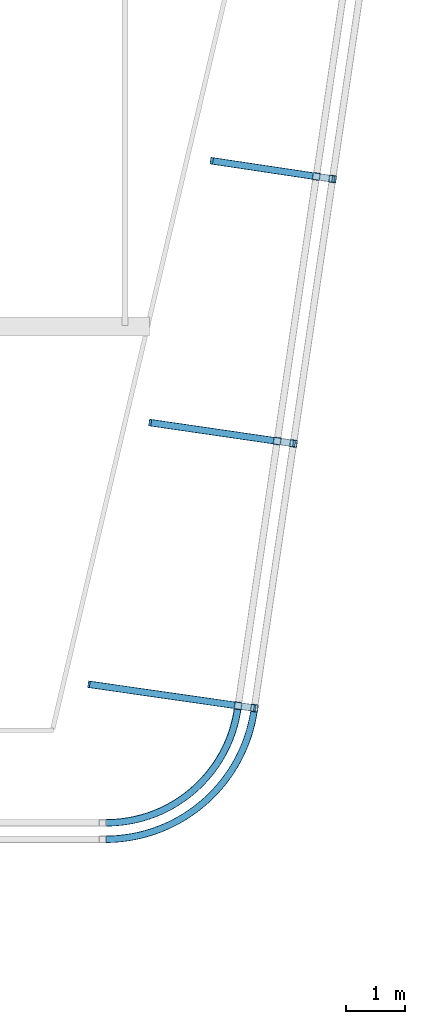
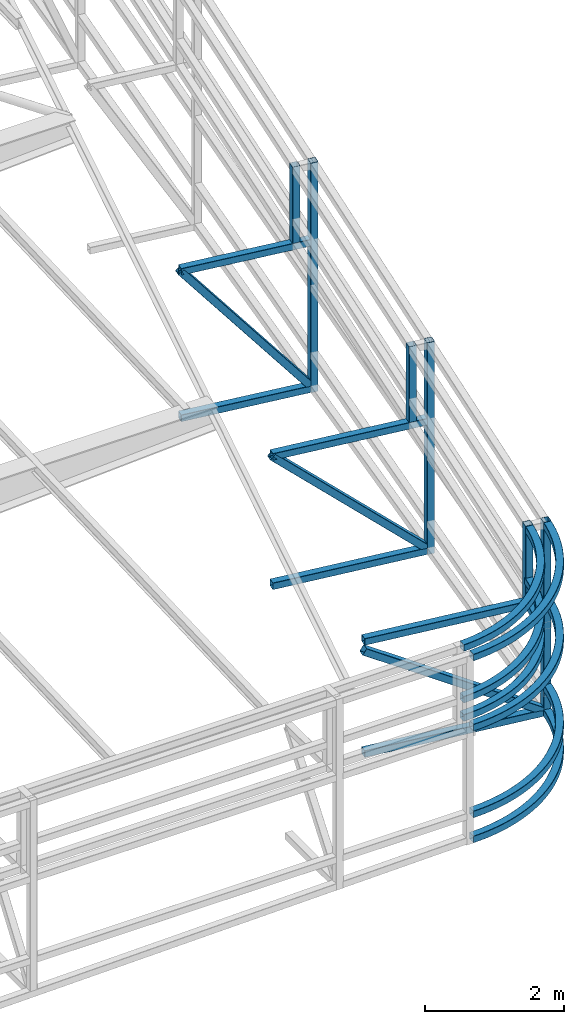
# One storey, part 118 of 215: 19 beams, 3 members, 22 elements without a shape of their own.
"""IFC2X3 building model written with IfcOpenShell, lengths in millimetres."""

from ifc_helpers import new_model, entity, si_unit, frame, origin_with_axes, origin_2d_with_axis, place, context, subcontext, project, spatial, hollow_rectangle, extrude, material, type_object, element, aggregate, save


model = new_model("IFC2X3")

# Units and contexts
model_context = context("Model", 3, precision=1e-05, world=origin_with_axes())
body_context = subcontext(model_context, "Body", "Model", "MODEL_VIEW")
ifc_project = project(units=[si_unit("LENGTHUNIT", "METRE", prefix="MILLI"), si_unit("AREAUNIT", "SQUARE_METRE"), si_unit("VOLUMEUNIT", "CUBIC_METRE"), si_unit("MASSUNIT", "GRAM", prefix="KILO"), si_unit("TIMEUNIT", "SECOND"), si_unit("PLANEANGLEUNIT", "RADIAN"), si_unit("SOLIDANGLEUNIT", "STERADIAN"), si_unit("THERMODYNAMICTEMPERATUREUNIT", "DEGREE_CELSIUS"), si_unit("LUMINOUSINTENSITYUNIT", "LUMEN")], contexts=[model_context])

# Site, building, storey
site_placement = place(None, origin_with_axes())
site = spatial("IfcSite", under=ifc_project, at=site_placement, CompositionType="ELEMENT")
building_placement = place(site_placement, origin_with_axes())
building = spatial("IfcBuilding", under=site, at=building_placement, Name="Undefined", CompositionType="ELEMENT")
storey_placement = place(building_placement, origin_with_axes())
storey = spatial("IfcBuildingStorey", under=building, at=storey_placement, Name="Undefined", CompositionType="ELEMENT", Elevation=0.0)

# Assembly, beam
assembly_1_placement = place(storey_placement, origin_with_axes())
assembly_1 = element("IfcElementAssembly", 1, at=assembly_1_placement, inside=storey, Name="Steel Assembly", AssemblyPlace="NOTDEFINED", PredefinedType="RIGID_FRAME")
ifc_material = material(Name="STEEL/S275JR")
beam_type = type_object("IfcBeamType", PredefinedType="NOTDEFINED")
beam_1_placement = place(assembly_1_placement, frame((146986.107821461, 33421.3509029512, 3370.20225622604), z_axis=(0.0249379879919667, 0.0219553309929332, -0.999447877678423), x_axis=(0.750140522937086, 0.660443226944612, 0.0332255899972135)))
beam_1 = element("IfcBeam", 2, at=beam_1_placement, type_object=beam_type, material=ifc_material, Name="LISSE", context=body_context, shape_type="SweptSolid", body=[
    entity("IfcRevolvedAreaSolid", entity("IfcRectangleHollowProfileDef", "AREA", None, entity("IfcAxis2Placement2D", entity("IfcCartesianPoint", [0.0, 0.0]), entity("IfcDirection", [1.0, 0.0])), 120.0, 120.0, 4.0, 4.0, 8.0), entity("IfcAxis2Placement3D", entity("IfcCartesianPoint", [2982.09033256195, -3.31258300091533e-13, 4.54747350886464e-13]), entity("IfcDirection", [-0.751481205288007, 0.659754498354414, 1.12605010136892e-18]), entity("IfcDirection", [-0.659754498354413, -0.751481205288007, -1.28260662034445e-18])), entity("IfcAxis1Placement", entity("IfcCartesianPoint", [2260.0, 0.0, 0.0]), entity("IfcDirection", [0.0, 1.0, 0.0])), 1.44098404733524),
])
aggregate(assembly_1, [beam_1])

assembly_2_placement = place(storey_placement, origin_with_axes())
assembly_2 = element("IfcElementAssembly", 3, at=assembly_2_placement, inside=storey, Name="Steel Assembly", AssemblyPlace="NOTDEFINED", PredefinedType="RIGID_FRAME")
beam_2_placement = place(assembly_2_placement, frame((149229.547572394, 35412.1655569566, 4443.67703251226), z_axis=(0.989924604068383, -0.141595474009783, 0.0), x_axis=(0.0, 0.0, -1.0)))
beam_2 = element("IfcBeam", 4, at=beam_2_placement, type_object=beam_type, material=ifc_material, Name="LISSE", context=body_context, shape_type="SweptSolid", body=[
    extrude(hollow_rectangle(XDim=120.0, YDim=120.0, WallThickness=4.0, InnerFilletRadius=4.0, OuterFilletRadius=8.0, at=origin_2d_with_axis()), frame((1326.42375686985, 0.0, 0.0), z_axis=(-1.0, 0.0, 0.0), x_axis=(-6.93889390390723e-18, -1.0, -3.46944695195361e-18)), (0.0, 0.0, 1.0), 1326.4),
])
aggregate(assembly_2, [beam_2])

assembly_3_placement = place(storey_placement, origin_with_axes())
assembly_3 = element("IfcElementAssembly", 5, at=assembly_3_placement, inside=storey, Name="Steel Assembly", AssemblyPlace="NOTDEFINED", PredefinedType="RIGID_FRAME")
beam_3_placement = place(assembly_3_placement, frame((146984.608837866, 33420.048579936, 3050.34013730541), z_axis=(0.00179264899915949, 0.00154833799926593, -0.999997194525568), x_axis=(0.756640650044633, 0.653826671038565, 0.00236874200013964)))
beam_3 = element("IfcBeam", 6, at=beam_3_placement, type_object=beam_type, material=ifc_material, Name="LISSE", context=body_context, shape_type="SweptSolid", body=[
    entity("IfcRevolvedAreaSolid", entity("IfcRectangleHollowProfileDef", "AREA", None, entity("IfcAxis2Placement2D", entity("IfcCartesianPoint", [0.0, 0.0]), entity("IfcDirection", [1.0, 0.0])), 120.0, 120.0, 4.0, 4.0, 8.0), entity("IfcAxis2Placement3D", entity("IfcCartesianPoint", [2955.85779626077, -1.44083565119215e-11, -4.54747350886464e-13]), entity("IfcDirection", [-0.756537044049607, 0.653950839880708, 4.02975277534255e-20]), entity("IfcDirection", [-0.653950839880708, -0.756537044049607, -4.66190586048407e-20])), entity("IfcAxis1Placement", entity("IfcCartesianPoint", [2260.0, 0.0, 0.0]), entity("IfcDirection", [0.0, 1.0, 0.0])), 1.42558999007248),
])
aggregate(assembly_3, [beam_3])

assembly_4_placement = place(storey_placement, origin_with_axes())
assembly_4 = element("IfcElementAssembly", 7, at=assembly_4_placement, inside=storey, Name="Steel Assembly", AssemblyPlace="NOTDEFINED", PredefinedType="RIGID_FRAME")
beam_4_placement = place(assembly_4_placement, frame((146985.996338329, 33421.2851109319, 4277.74721442107), z_axis=(0.0253519010019989, 0.0218986280017402, -0.999438708079303), x_axis=(0.756342078056285, 0.653317987048616, 0.0335002800024929)))
beam_4 = element("IfcBeam", 8, at=beam_4_placement, type_object=beam_type, material=ifc_material, Name="LISSE", context=body_context, shape_type="SweptSolid", body=[
    entity("IfcRevolvedAreaSolid", entity("IfcRectangleHollowProfileDef", "AREA", None, entity("IfcAxis2Placement2D", entity("IfcCartesianPoint", [0.0, 0.0]), entity("IfcDirection", [1.0, 0.0])), 120.0, 120.0, 4.0, 4.0, 8.0), entity("IfcAxis2Placement3D", entity("IfcCartesianPoint", [2957.63905920273, -1.46888710049272e-11, 9.53714342788421e-13]), entity("IfcDirection", [-0.756196217688976, 0.654344924602374, 1.39294531843258e-17]), entity("IfcDirection", [-0.654344924602374, -0.756196217688976, 5.11104750660968e-18])), entity("IfcAxis1Placement", entity("IfcCartesianPoint", [2260.0, 0.0, 0.0]), entity("IfcDirection", [0.0, 1.0, 0.0])), 1.42663203687007),
])
aggregate(assembly_4, [beam_4])

assembly_5_placement = place(storey_placement, origin_with_axes())
assembly_5 = element("IfcElementAssembly", 9, at=assembly_5_placement, inside=storey, Name="Steel Assembly", AssemblyPlace="NOTDEFINED", PredefinedType="RIGID_FRAME")
beam_5_placement = place(assembly_5_placement, frame((146985.775961301, 33141.0905904749, 4280.15728586742), z_axis=(0.0214822509927782, 0.0185404799937631, -0.999597300663564), x_axis=(0.756721212900151, 0.653121557913824, 0.0283766899962559)))
beam_5 = element("IfcBeam", 10, at=beam_5_placement, type_object=beam_type, material=ifc_material, Name="LISSE", context=body_context, shape_type="SweptSolid", body=[
    entity("IfcRevolvedAreaSolid", entity("IfcRectangleHollowProfileDef", "AREA", None, entity("IfcAxis2Placement2D", entity("IfcCartesianPoint", [0.0, 0.0]), entity("IfcDirection", [1.0, 0.0])), 120.0, 120.0, 4.0, 4.0, 8.0), entity("IfcAxis2Placement3D", entity("IfcCartesianPoint", [3321.12292680895, 1.47960032481586e-11, 9.09494701772928e-13]), entity("IfcDirection", [-0.761081025736955, 0.648656821642373, -1.46472156336757e-18]), entity("IfcDirection", [-0.648656821642373, -0.761081025736955, 1.71858485515387e-18])), entity("IfcAxis1Placement", entity("IfcCartesianPoint", [2560.0, 0.0, 0.0]), entity("IfcDirection", [0.0, 1.0, 0.0])), 1.41163655377641),
])
aggregate(assembly_5, [beam_5])

assembly_6_placement = place(storey_placement, origin_with_axes())
assembly_6 = element("IfcElementAssembly", 11, at=assembly_6_placement, inside=storey, Name="Steel Assembly", AssemblyPlace="NOTDEFINED", PredefinedType="RIGID_FRAME")
beam_6_placement = place(assembly_6_placement, frame((146984.478276513, 33139.987285832, 3051.71855063196), z_axis=(0.0, 0.0, -1.0), x_axis=(0.757026076418502, 0.653384664361208, 1.00000000707343e-08)))
beam_6 = element("IfcBeam", 12, at=beam_6_placement, type_object=beam_type, material=ifc_material, Name="LISSE", context=body_context, shape_type="SweptSolid", body=[
    entity("IfcRevolvedAreaSolid", entity("IfcRectangleHollowProfileDef", "AREA", None, entity("IfcAxis2Placement2D", entity("IfcCartesianPoint", [0.0, 0.0]), entity("IfcDirection", [1.0, 0.0])), 120.0, 120.0, 4.0, 4.0, 8.0), entity("IfcAxis2Placement3D", entity("IfcCartesianPoint", [3319.78546821593, 1.48220415771816e-11, 4.54747147677863e-13]), entity("IfcDirection", [-0.761303583900054, 0.648395599260924, -2.2051122628262e-23]), entity("IfcDirection", [-0.648395599260925, -0.761303583900054, 1.20295332207293e-22])), entity("IfcAxis1Placement", entity("IfcCartesianPoint", [2560.0, 0.0, 0.0]), entity("IfcDirection", [0.0, 1.0, 0.0])), 1.4109502032255),
])
aggregate(assembly_6, [beam_6])

assembly_7_placement = place(storey_placement, origin_with_axes())
assembly_7 = element("IfcElementAssembly", 13, at=assembly_7_placement, inside=storey, Name="Steel Assembly", AssemblyPlace="NOTDEFINED", PredefinedType="RIGID_FRAME")
beam_7_placement = place(assembly_7_placement, frame((146984.478275593, 33139.9863115836, 1528.87963197618), z_axis=(0.0, 0.0, -1.0), x_axis=(0.757026076418502, 0.653384664361208, 1.00000000707343e-08)))
beam_7 = element("IfcBeam", 14, at=beam_7_placement, type_object=beam_type, material=ifc_material, Name="LISSE", context=body_context, shape_type="SweptSolid", body=[
    entity("IfcRevolvedAreaSolid", entity("IfcRectangleHollowProfileDef", "AREA", None, entity("IfcAxis2Placement2D", entity("IfcCartesianPoint", [0.0, 0.0]), entity("IfcDirection", [1.0, 0.0])), 120.0, 120.0, 4.0, 4.0, 8.0), entity("IfcAxis2Placement3D", entity("IfcCartesianPoint", [3319.78546821593, 1.48220415771816e-11, 4.54747147677863e-13]), entity("IfcDirection", [-0.761303583900054, 0.648395599260924, -2.2051122628262e-23]), entity("IfcDirection", [-0.648395599260925, -0.761303583900054, 1.20295332207293e-22])), entity("IfcAxis1Placement", entity("IfcCartesianPoint", [2560.0, 0.0, 0.0]), entity("IfcDirection", [0.0, 1.0, 0.0])), 1.41095020268318),
])
aggregate(assembly_7, [beam_7])

assembly_8_placement = place(storey_placement, origin_with_axes())
assembly_8 = element("IfcElementAssembly", 15, at=assembly_8_placement, inside=storey, Name="Steel Assembly", AssemblyPlace="NOTDEFINED", PredefinedType="RIGID_FRAME")
beam_8_placement = place(assembly_8_placement, frame((150559.754278982, 44413.5248230028, 4817.75277962869), z_axis=(0.989008242586695, -0.147860393938214, -1.14999999775283e-07), x_axis=(9.82199999785384e-06, 6.6470999981142e-05, -0.999999997742567)))
beam_8 = element("IfcBeam", 16, at=beam_8_placement, type_object=beam_type, material=ifc_material, Name="LISSE", context=body_context, shape_type="SweptSolid", body=[
    extrude(hollow_rectangle(XDim=120.0, YDim=120.0, WallThickness=4.0, InnerFilletRadius=4.0, OuterFilletRadius=8.0, at=origin_2d_with_axis()), frame((1339.42166511812, 0.0, 4.25450355232975e-19), z_axis=(-1.0, 0.0, 0.0), x_axis=(-6.93889390390723e-18, -1.0, -3.46944695195361e-18)), (0.0, 0.0, 1.0), 1339.4),
])
aggregate(assembly_8, [beam_8])

assembly_9_placement = place(storey_placement, origin_with_axes())
assembly_9 = element("IfcElementAssembly", 17, at=assembly_9_placement, inside=storey, Name="Steel Assembly", AssemblyPlace="NOTDEFINED", PredefinedType="RIGID_FRAME")
beam_9_placement = place(assembly_9_placement, frame((150836.550065716, 44371.8015430601, 4817.75278122506), z_axis=(0.989008242586695, -0.147860393938214, -1.14999999775283e-07), x_axis=(0.0, 0.0, -1.0)))
beam_9 = element("IfcBeam", 18, at=beam_9_placement, type_object=beam_type, material=ifc_material, Name="LISSE", context=body_context, shape_type="SweptSolid", body=[
    extrude(hollow_rectangle(XDim=120.0, YDim=120.0, WallThickness=4.0, InnerFilletRadius=4.0, OuterFilletRadius=8.0, at=origin_2d_with_axis()), frame((4028.88398977728, 0.0, 0.0), z_axis=(-1.0, 0.0, 0.0), x_axis=(-6.93889390390723e-18, -1.0, -3.46944695195361e-18)), (0.0, 0.0, 1.0), 4028.9),
])
aggregate(assembly_9, [beam_9])

assembly_10_placement = place(storey_placement, origin_with_axes())
assembly_10 = element("IfcElementAssembly", 19, at=assembly_10_placement, inside=storey, Name="Steel Assembly", AssemblyPlace="NOTDEFINED", PredefinedType="RIGID_FRAME")
beam_10_placement = place(assembly_10_placement, frame((148802.604779655, 44677.2956269249, 3418.33112434851), z_axis=(0.0, 0.0, 1.0), x_axis=(0.98891981087804, -0.148450690981692, 0.0)))
beam_10 = element("IfcBeam", 20, at=beam_10_placement, type_object=beam_type, material=ifc_material, Name="LISSE", context=body_context, shape_type="SweptSolid", body=[
    extrude(hollow_rectangle(XDim=120.0, YDim=120.0, WallThickness=4.0, InnerFilletRadius=4.0, OuterFilletRadius=8.0, at=origin_2d_with_axis()), frame((2046.83693117877, 1.45519152283669e-11, 0.0), z_axis=(-1.0, 0.0, 0.0), x_axis=(-6.93889390390723e-18, -1.0, -3.46944695195361e-18)), (0.0, 0.0, 1.0), 2046.8),
])
aggregate(assembly_10, [beam_10])

assembly_11_placement = place(storey_placement, origin_with_axes())
assembly_11 = element("IfcElementAssembly", 21, at=assembly_11_placement, inside=storey, Name="Steel Assembly", AssemblyPlace="NOTDEFINED", PredefinedType="RIGID_FRAME")
beam_11_placement = place(assembly_11_placement, frame((148802.591639564, 44677.2067034657, 848.868796747961), z_axis=(0.0, 0.0, 1.0), x_axis=(0.988919944781477, -0.148449798967196, 0.0)))
beam_11 = element("IfcBeam", 22, at=beam_11_placement, type_object=beam_type, material=ifc_material, Name="LISSE", context=body_context, shape_type="SweptSolid", body=[
    extrude(hollow_rectangle(XDim=120.0, YDim=120.0, WallThickness=4.0, InnerFilletRadius=4.0, OuterFilletRadius=8.0, at=origin_2d_with_axis()), frame((2046.83701684264, 1.4495104088773e-11, -8.12689870746292e-20), z_axis=(-1.0, 0.0, 0.0), x_axis=(-6.93889390390723e-18, -1.0, -3.46944695195361e-18)), (0.0, 0.0, 1.0), 2046.8),
])
aggregate(assembly_11, [beam_11])

assembly_12_placement = place(storey_placement, origin_with_axes())
assembly_12 = element("IfcElementAssembly", 23, at=assembly_12_placement, inside=storey, Name="Steel Assembly", AssemblyPlace="NOTDEFINED", PredefinedType="RIGID_FRAME")
beam_12_placement = place(assembly_12_placement, frame((149894.828068224, 39912.8547542987, 4626.55931463744), z_axis=(0.989369699093649, -0.145422139013767, 5.09999999897515e-08), x_axis=(9.82199999785384e-06, 6.6470999981142e-05, -0.999999997742567)))
beam_12 = element("IfcBeam", 24, at=beam_12_placement, type_object=beam_type, material=ifc_material, Name="LISSE", context=body_context, shape_type="SweptSolid", body=[
    extrude(hollow_rectangle(XDim=120.0, YDim=120.0, WallThickness=4.0, InnerFilletRadius=4.0, OuterFilletRadius=8.0, at=origin_2d_with_axis()), frame((1328.10102284344, 3.59982503561769e-17, -2.91038295163497e-11), z_axis=(-1.0, 0.0, 0.0), x_axis=(-6.93889390390723e-18, -1.0, -3.46944695195361e-18)), (0.0, 0.0, 1.0), 1328.1),
])
aggregate(assembly_12, [beam_12])

assembly_13_placement = place(storey_placement, origin_with_axes())
assembly_13 = element("IfcElementAssembly", 25, at=assembly_13_placement, inside=storey, Name="Steel Assembly", AssemblyPlace="NOTDEFINED", PredefinedType="RIGID_FRAME")
beam_13_placement = place(assembly_13_placement, frame((150171.856743916, 39872.1743222594, 4626.55930628644), z_axis=(0.989369699093649, -0.145422139013767, 5.09999999897515e-08), x_axis=(0.0, 0.0, -1.0)))
beam_13 = element("IfcBeam", 26, at=beam_13_placement, type_object=beam_type, material=ifc_material, Name="LISSE", context=body_context, shape_type="SweptSolid", body=[
    extrude(hollow_rectangle(XDim=120.0, YDim=120.0, WallThickness=4.0, InnerFilletRadius=4.0, OuterFilletRadius=8.0, at=origin_2d_with_axis()), frame((3717.80955508578, 0.0, 0.0), z_axis=(-1.0, 0.0, 0.0), x_axis=(-6.93889390390723e-18, -1.0, -3.46944695195361e-18)), (0.0, 0.0, 1.0), 3717.8),
])
aggregate(assembly_13, [beam_13])

assembly_14_placement = place(storey_placement, origin_with_axes())
assembly_14 = element("IfcElementAssembly", 27, at=assembly_14_placement, inside=storey, Name="Steel Assembly", AssemblyPlace="NOTDEFINED", PredefinedType="RIGID_FRAME")
beam_14_placement = place(assembly_14_placement, frame((147753.372346972, 40224.4947308677, 3238.45829173692), z_axis=(0.0, 0.0, 1.0), x_axis=(0.989558721916091, -0.144130273987778, 0.0)))
beam_14 = element("IfcBeam", 28, at=beam_14_placement, type_object=beam_type, material=ifc_material, Name="LISSE", context=body_context, shape_type="SweptSolid", body=[
    extrude(hollow_rectangle(XDim=120.0, YDim=120.0, WallThickness=4.0, InnerFilletRadius=4.0, OuterFilletRadius=8.0, at=origin_2d_with_axis()), frame((2434.01302481014, 6.75574325595442e-14, 4.54747350886464e-13), z_axis=(-1.0, 0.0, 0.0), x_axis=(-6.93889390390723e-18, -1.0, -3.46944695195361e-18)), (0.0, 0.0, 1.0), 2434.0),
])
aggregate(assembly_14, [beam_14])

assembly_15_placement = place(storey_placement, origin_with_axes())
assembly_15 = element("IfcElementAssembly", 29, at=assembly_15_placement, inside=storey, Name="Steel Assembly", AssemblyPlace="NOTDEFINED", PredefinedType="RIGID_FRAME")
beam_15_placement = place(assembly_15_placement, frame((147753.359206235, 40224.4058074942, 968.749756541968), z_axis=(0.0, 0.0, 1.0), x_axis=(0.989558721916091, -0.144130273987778, 0.0)))
beam_15 = element("IfcBeam", 30, at=beam_15_placement, type_object=beam_type, material=ifc_material, Name="LISSE", context=body_context, shape_type="SweptSolid", body=[
    extrude(hollow_rectangle(XDim=120.0, YDim=120.0, WallThickness=4.0, InnerFilletRadius=4.0, OuterFilletRadius=8.0, at=origin_2d_with_axis()), frame((2434.01311404743, -7.27595761418343e-12, 1.13686837721616e-13), z_axis=(-1.0, 0.0, 0.0), x_axis=(-6.93889390390723e-18, -1.0, -3.46944695195361e-18)), (0.0, 0.0, 1.0), 2434.0),
])
aggregate(assembly_15, [beam_15])

assembly_16_placement = place(storey_placement, origin_with_axes())
assembly_16 = element("IfcElementAssembly", 31, at=assembly_16_placement, inside=storey, Name="Steel Assembly", AssemblyPlace="NOTDEFINED", PredefinedType="RIGID_FRAME")
beam_16_placement = place(assembly_16_placement, frame((149507.183886388, 35372.43040731, 4435.47433145221), z_axis=(0.989924604068383, -0.141595474009783, 0.0), x_axis=(0.0, 0.0, -1.0)))
beam_16 = element("IfcBeam", 32, at=beam_16_placement, type_object=beam_type, material=ifc_material, Name="LISSE", context=body_context, shape_type="SweptSolid", body=[
    extrude(hollow_rectangle(XDim=120.0, YDim=120.0, WallThickness=4.0, InnerFilletRadius=4.0, OuterFilletRadius=8.0, at=origin_2d_with_axis()), frame((3405.4721543711, 0.0, 0.0), z_axis=(-1.0, 0.0, 0.0), x_axis=(-6.93889390390723e-18, -1.0, -3.46944695195361e-18)), (0.0, 0.0, 1.0), 3405.5),
])
aggregate(assembly_16, [beam_16])

assembly_17_placement = place(storey_placement, origin_with_axes())
assembly_17 = element("IfcElementAssembly", 33, at=assembly_17_placement, inside=storey, Name="Steel Assembly", AssemblyPlace="NOTDEFINED", PredefinedType="RIGID_FRAME")
beam_17_placement = place(assembly_17_placement, frame((146984.478278106, 33139.9859947302, 1090.00212169666), z_axis=(0.0, 0.0, -1.0), x_axis=(0.757026076418502, 0.653384664361208, 1.00000000707343e-08)))
beam_17 = element("IfcBeam", 34, at=beam_17_placement, type_object=beam_type, material=ifc_material, Name="LISSE", context=body_context, shape_type="SweptSolid", body=[
    entity("IfcRevolvedAreaSolid", entity("IfcRectangleHollowProfileDef", "AREA", None, entity("IfcAxis2Placement2D", entity("IfcCartesianPoint", [0.0, 0.0]), entity("IfcDirection", [1.0, 0.0])), 120.0, 120.0, 4.0, 4.0, 8.0), entity("IfcAxis2Placement3D", entity("IfcCartesianPoint", [3319.78546821593, 1.48220415771816e-11, 4.54747147677863e-13]), entity("IfcDirection", [-0.761303583900054, 0.648395599260924, -2.2051122628262e-23]), entity("IfcDirection", [-0.648395599260925, -0.761303583900054, 1.20295332207293e-22])), entity("IfcAxis1Placement", entity("IfcCartesianPoint", [2560.0, 0.0, 0.0]), entity("IfcDirection", [0.0, 1.0, 0.0])), 1.41095020388298),
])
aggregate(assembly_17, [beam_17])

assembly_18_placement = place(storey_placement, origin_with_axes())
assembly_18 = element("IfcElementAssembly", 35, at=assembly_18_placement, inside=storey, Name="Steel Assembly", AssemblyPlace="NOTDEFINED", PredefinedType="RIGID_FRAME")
beam_18_placement = place(assembly_18_placement, frame((146707.221385807, 35774.2419803963, 3057.25327571789), z_axis=(0.0, 0.0, 1.0), x_axis=(0.989847912260334, -0.142130611037381, 0.0)))
beam_18 = element("IfcBeam", 36, at=beam_18_placement, type_object=beam_type, material=ifc_material, Name="LISSE", context=body_context, shape_type="SweptSolid", body=[
    extrude(hollow_rectangle(XDim=120.0, YDim=120.0, WallThickness=4.0, InnerFilletRadius=4.0, OuterFilletRadius=8.0, at=origin_2d_with_axis()), frame((2818.18172215405, -7.1977373582956e-12, 3.72983245314741e-20), z_axis=(-1.0, 0.0, 0.0), x_axis=(-6.93889390390723e-18, -1.0, -3.46944695195361e-18)), (0.0, 0.0, 1.0), 2818.2),
])
aggregate(assembly_18, [beam_18])

assembly_19_placement = place(storey_placement, origin_with_axes())
assembly_19 = element("IfcElementAssembly", 37, at=assembly_19_placement, inside=storey, Name="Steel Assembly", AssemblyPlace="NOTDEFINED", PredefinedType="RIGID_FRAME")
beam_19_placement = place(assembly_19_placement, frame((146707.200037328, 35774.2451559997, 1090.00218247215), z_axis=(0.0, 0.0, 1.0), x_axis=(0.989847912260334, -0.142130611037381, 0.0)))
beam_19 = element("IfcBeam", 38, at=beam_19_placement, type_object=beam_type, material=ifc_material, Name="LISSE", context=body_context, shape_type="SweptSolid", body=[
    extrude(hollow_rectangle(XDim=120.0, YDim=120.0, WallThickness=4.0, InnerFilletRadius=4.0, OuterFilletRadius=8.0, at=origin_2d_with_axis()), frame((2818.1818080206, 7.82202582711057e-14, -2.27373712741558e-13), z_axis=(-1.0, 0.0, 0.0), x_axis=(-6.93889390390723e-18, -1.0, -3.46944695195361e-18)), (0.0, 0.0, 1.0), 2818.2),
])
aggregate(assembly_19, [beam_19])

# Assembly, member
assembly_20_placement = place(storey_placement, origin_with_axes())
assembly_20 = element("IfcElementAssembly", 39, at=assembly_20_placement, inside=storey, Name="Steel Assembly", AssemblyPlace="NOTDEFINED", PredefinedType="RIGID_FRAME")
member_type = type_object("IfcMemberType", PredefinedType="NOTDEFINED")
member_1_placement = place(assembly_20_placement, frame((150826.756420091, 44373.3627595296, 848.868796718676), z_axis=(0.773246994440423, -0.117772849067084, 0.623071939354898), x_axis=(-0.616165042115918, 0.0925220710174063, 0.782163862147146)))
member_1 = element("IfcMember", 40, at=member_1_placement, type_object=member_type, material=ifc_material, Name="LISSE", context=body_context, shape_type="SweptSolid", body=[
    extrude(hollow_rectangle(XDim=120.0, YDim=120.0, WallThickness=4.0, InnerFilletRadius=4.0, OuterFilletRadius=8.0, at=origin_2d_with_axis()), frame((3285.06909072723, -2.38632496010406e-14, 1.49166311625678e-11), z_axis=(-1.0, 0.0, 0.0), x_axis=(-6.93889390390723e-18, -1.0, -3.46944695195361e-18)), (0.0, 0.0, 1.0), 3285.1),
])
aggregate(assembly_20, [member_1])

assembly_21_placement = place(storey_placement, origin_with_axes())
assembly_21 = element("IfcElementAssembly", 41, at=assembly_21_placement, inside=storey, Name="Steel Assembly", AssemblyPlace="NOTDEFINED", PredefinedType="RIGID_FRAME")
member_2_placement = place(assembly_21_placement, frame((150161.953294713, 39873.6027024489, 968.749756503414), z_axis=(0.674653445265512, -0.0997932500392759, 0.731357666287825), x_axis=(-0.723718335417538, 0.10543714906083, 0.681993239393465)))
member_2 = element("IfcMember", 42, at=member_2_placement, type_object=member_type, material=ifc_material, Name="LISSE", context=body_context, shape_type="SweptSolid", body=[
    extrude(hollow_rectangle(XDim=120.0, YDim=120.0, WallThickness=4.0, InnerFilletRadius=4.0, OuterFilletRadius=8.0, at=origin_2d_with_axis()), frame((3328.05136983971, 1.46316582279765e-11, 1.43671712654703e-11), z_axis=(-1.0, 0.0, 0.0), x_axis=(-6.93889390390723e-18, -1.0, -3.46944695195361e-18)), (0.0, 0.0, 1.0), 3328.1),
])
aggregate(assembly_21, [member_2])

assembly_22_placement = place(storey_placement, origin_with_axes())
assembly_22 = element("IfcElementAssembly", 43, at=assembly_22_placement, inside=storey, Name="Steel Assembly", AssemblyPlace="NOTDEFINED", PredefinedType="RIGID_FRAME")
member_3_placement = place(assembly_22_placement, frame((149496.777345755, 35373.6961185501, 1090.00218246585), z_axis=(0.531326100191176, -0.07743212702786, 0.843621266303534), x_axis=(-0.835057355076409, 0.119903966010971, 0.536937848049132)))
member_3 = element("IfcMember", 44, at=member_3_placement, type_object=member_type, material=ifc_material, Name="LISSE", context=body_context, shape_type="SweptSolid", body=[
    extrude(hollow_rectangle(XDim=120.0, YDim=120.0, WallThickness=4.0, InnerFilletRadius=4.0, OuterFilletRadius=8.0, at=origin_2d_with_axis()), frame((3340.57489304813, 6.84531267158339e-14, 0.0), z_axis=(-1.0, 0.0, 0.0), x_axis=(-6.93889390390723e-18, -1.0, -3.46944695195361e-18)), (0.0, 0.0, 1.0), 3340.6),
])
aggregate(assembly_22, [member_3])

save(model, "model.ifc")
